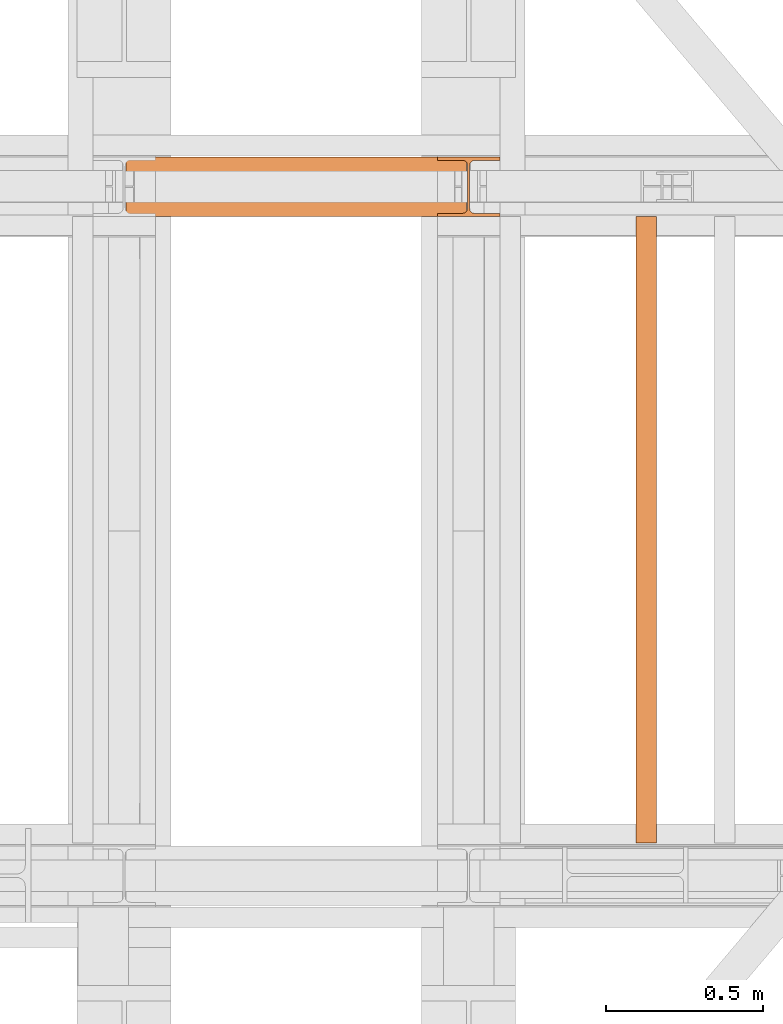
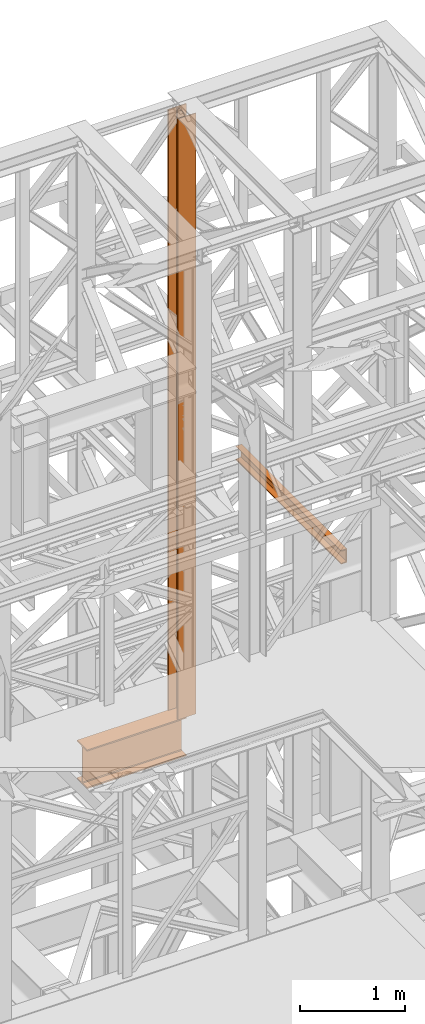
# One storey, part 171 of 208: 3 proxies.
"""IFC2X3 building model written with IfcOpenShell, lengths in millimetres."""

from ifc_helpers import new_model, entity, si_unit, converted_unit, frame, origin, origin_with_axes, place, context, subcontext, project, spatial, faceted_brep, element, save


model = new_model("IFC2X3")

# Units and contexts
model_context = context("Model", 3, precision=1e-05, world=origin())
plan_context = context("Plan", 3, precision=1e-05, world=origin())
body_context = subcontext(model_context, "Body", "Model", "MODEL_VIEW")
ifc_project = project(units=[si_unit("LENGTHUNIT", "METRE", prefix="MILLI"), converted_unit("PLANEANGLEUNIT", "DEGREE", entity("IfcPlaneAngleMeasure", 0.0174532925199433), si_unit("PLANEANGLEUNIT", "RADIAN"), dimensions=[0, 0, 0, 0, 0, 0, 0]), si_unit("AREAUNIT", "SQUARE_METRE"), si_unit("VOLUMEUNIT", "CUBIC_METRE")], contexts=[model_context, plan_context])

# Building, storey
building_placement = place(None, origin())
building = spatial("IfcBuilding", under=ifc_project, at=building_placement, CompositionType="COMPLEX")
storey_placement = place(building_placement, origin_with_axes())
storey = spatial("IfcBuildingStorey", under=building, at=storey_placement, Name="Geschoss", CompositionType="ELEMENT")

# Proxies
proxy_1_placement = place(storey_placement, frame((5499.254968580828, -13857.57439657637, 4834.989987483023), z_axis=(0.0, 0.0, 1.0), x_axis=(1.0, 0.0, 0.0)))
element("IfcBuildingElementProxy", 1, at=proxy_1_placement, inside=storey, context=body_context, shape_type="Brep", body=[
    faceted_brep([(1088.009999895696, 0.01000000000021828, 450.0100178813937), (1088.009999895696, 190.0100125169756, 450.0100178813937), (1088.009999895696, 190.0100125169756, 435.4100240564349), (1088.009999895696, 120.7100073045494, 435.4100091552737), (1088.009999895696, 109.841562265754, 433.2347078418734), (1088.009999895696, 101.8853126263621, 425.2784563398363), (1088.009999895696, 99.71000619068764, 414.4100113010409), (1088.009999895696, 99.71000619068764, 35.60999167919181), (1088.009999895696, 101.8853126263621, 24.74154664039634), (1088.009999895696, 109.841562265754, 16.78529513835929), (1088.009999895696, 120.7100073045494, 14.60999382495902), (1088.009999895696, 190.0100125169756, 14.60999382495902), (1088.009999895696, 190.0100125169756, 0.01000000000021828), (1088.009999895696, 0.01000000000021828, 0.01000000000021828), (1088.009999895696, 0.01000000000021828, 14.60999382495902), (1088.009999895696, 69.3100052124264, 14.60999382495902), (1088.009999895696, 80.17845025122188, 16.78529513835929), (1088.009999895696, 88.13469989061377, 24.74154664039634), (1088.009999895696, 90.3100063262882, 35.60999167919181), (1088.009999895696, 90.3100063262882, 414.4100113010409), (1088.009999895696, 88.13469989061377, 425.2784563398363), (1088.009999895696, 80.17845025122188, 433.2347078418734), (1088.009999895696, 69.3100052124264, 435.4100091552737), (1088.009999895696, 0.01000000000021828, 435.4100240564349), (1088.009999895696, 190.0100125169756, 450.0100178813937), (1088.009999895696, 0.01000000000021828, 450.0100178813937), (0.01000000000021828, 0.01000000000021828, 450.0100178813937), (0.01000000000021828, 190.0100125169756, 450.0100178813937), (1088.009999895696, 190.0100125169756, 435.4100240564349), (1088.009999895696, 190.0100125169756, 450.0100178813937), (0.01000000000021828, 190.0100125169756, 450.0100178813937), (0.01000000000021828, 190.0100125169756, 435.4100240564349), (1088.009999895696, 120.7100073045494, 435.4100091552737), (1088.009999895696, 190.0100125169756, 435.4100240564349), (0.01000000000021828, 190.0100125169756, 435.4100240564349), (0.01000000000021828, 120.7100073045494, 435.4100091552737), (1088.009999895696, 109.841562265754, 433.2347078418734), (1088.009999895696, 120.7100073045494, 435.4100091552737), (0.01000000000021828, 120.7100073045494, 435.4100091552737), (0.01000000000021828, 109.841562265754, 433.2347078418734), (1088.009999895696, 101.8853126263621, 425.2784563398363), (1088.009999895696, 109.841562265754, 433.2347078418734), (0.01000000000021828, 109.841562265754, 433.2347078418734), (0.01000000000021828, 101.8853126263621, 425.2784563398363), (1088.009999895696, 99.71000619068764, 414.4100113010409), (1088.009999895696, 101.8853126263621, 425.2784563398363), (0.01000000000021828, 101.8853126263621, 425.2784563398363), (0.01000000000021828, 99.71000619068764, 414.4100113010409), (1088.009999895696, 99.71000619068764, 35.60999167919181), (1088.009999895696, 99.71000619068764, 414.4100113010409), (0.01000000000021828, 99.71000619068764, 414.4100113010409), (0.01000000000021828, 99.71000619068764, 35.60999167919181), (1088.009999895696, 101.8853126263621, 24.74154664039634), (1088.009999895696, 99.71000619068764, 35.60999167919181), (0.01000000000021828, 99.71000619068764, 35.60999167919181), (0.01000000000021828, 101.8853126263621, 24.74154664039634), (1088.009999895696, 109.841562265754, 16.78529513835929), (1088.009999895696, 101.8853126263621, 24.74154664039634), (0.01000000000021828, 101.8853126263621, 24.74154664039634), (0.01000000000021828, 109.841562265754, 16.78529513835929), (1088.009999895696, 120.7100073045494, 14.60999382495902), (1088.009999895696, 109.841562265754, 16.78529513835929), (0.01000000000021828, 109.841562265754, 16.78529513835929), (0.01000000000021828, 120.7100073045494, 14.60999382495902), (1088.009999895696, 190.0100125169756, 14.60999382495902), (1088.009999895696, 120.7100073045494, 14.60999382495902), (0.01000000000021828, 120.7100073045494, 14.60999382495902), (0.01000000000021828, 190.0100125169756, 14.60999382495902), (1088.009999895696, 190.0100125169756, 0.01000000000021828), (1088.009999895696, 190.0100125169756, 14.60999382495902), (0.01000000000021828, 190.0100125169756, 14.60999382495902), (0.01000000000021828, 190.0100125169756, 0.01000000000021828), (1088.009999895696, 0.01000000000021828, 0.01000000000021828), (1088.009999895696, 190.0100125169756, 0.01000000000021828), (0.01000000000021828, 190.0100125169756, 0.01000000000021828), (0.01000000000021828, 0.01000000000021828, 0.01000000000021828), (1088.009999895696, 0.01000000000021828, 14.60999382495902), (1088.009999895696, 0.01000000000021828, 0.01000000000021828), (0.01000000000021828, 0.01000000000021828, 0.01000000000021828), (0.01000000000021828, 0.01000000000021828, 14.60999382495902), (1088.009999895696, 69.3100052124264, 14.60999382495902), (1088.009999895696, 0.01000000000021828, 14.60999382495902), (0.01000000000021828, 0.01000000000021828, 14.60999382495902), (0.01000000000021828, 69.3100052124264, 14.60999382495902), (1088.009999895696, 80.17845025122188, 16.78529513835929), (1088.009999895696, 69.3100052124264, 14.60999382495902), (0.01000000000021828, 69.3100052124264, 14.60999382495902), (0.01000000000021828, 80.17845025122188, 16.78529513835929), (1088.009999895696, 88.13469989061377, 24.74154664039634), (1088.009999895696, 80.17845025122188, 16.78529513835929), (0.01000000000021828, 80.17845025122188, 16.78529513835929), (0.01000000000021828, 88.13469989061377, 24.74154664039634), (1088.009999895696, 90.3100063262882, 35.60999167919181), (1088.009999895696, 88.13469989061377, 24.74154664039634), (0.01000000000021828, 88.13469989061377, 24.74154664039634), (0.01000000000021828, 90.3100063262882, 35.60999167919181), (1088.009999895696, 90.3100063262882, 414.4100113010409), (1088.009999895696, 90.3100063262882, 35.60999167919181), (0.01000000000021828, 90.3100063262882, 35.60999167919181), (0.01000000000021828, 90.3100063262882, 414.4100113010409), (1088.009999895696, 88.13469989061377, 425.2784563398363), (1088.009999895696, 90.3100063262882, 414.4100113010409), (0.01000000000021828, 90.3100063262882, 414.4100113010409), (0.01000000000021828, 88.13469989061377, 425.2784563398363), (1088.009999895696, 80.17845025122188, 433.2347078418734), (1088.009999895696, 88.13469989061377, 425.2784563398363), (0.01000000000021828, 88.13469989061377, 425.2784563398363), (0.01000000000021828, 80.17845025122188, 433.2347078418734), (1088.009999895696, 69.3100052124264, 435.4100091552737), (1088.009999895696, 80.17845025122188, 433.2347078418734), (0.01000000000021828, 80.17845025122188, 433.2347078418734), (0.01000000000021828, 69.3100052124264, 435.4100091552737), (1088.009999895696, 0.01000000000021828, 435.4100240564349), (1088.009999895696, 69.3100052124264, 435.4100091552737), (0.01000000000021828, 69.3100052124264, 435.4100091552737), (0.01000000000021828, 0.01000000000021828, 435.4100240564349), (1088.009999895696, 0.01000000000021828, 450.0100178813937), (1088.009999895696, 0.01000000000021828, 435.4100240564349), (0.01000000000021828, 0.01000000000021828, 435.4100240564349), (0.01000000000021828, 0.01000000000021828, 450.0100178813937), (0.01000000000021828, 0.01000000000021828, 450.0100178813937), (0.01000000000021828, 0.01000000000021828, 435.4100240564349), (0.01000000000021828, 69.3100052124264, 435.4100091552737), (0.01000000000021828, 80.17845025122188, 433.2347078418734), (0.01000000000021828, 88.13469989061377, 425.2784563398363), (0.01000000000021828, 90.3100063262882, 414.4100113010409), (0.01000000000021828, 90.3100063262882, 35.60999167919181), (0.01000000000021828, 88.13469989061377, 24.74154664039634), (0.01000000000021828, 80.17845025122188, 16.78529513835929), (0.01000000000021828, 69.3100052124264, 14.60999382495902), (0.01000000000021828, 0.01000000000021828, 14.60999382495902), (0.01000000000021828, 0.01000000000021828, 0.01000000000021828), (0.01000000000021828, 190.0100125169756, 0.01000000000021828), (0.01000000000021828, 190.0100125169756, 14.60999382495902), (0.01000000000021828, 120.7100073045494, 14.60999382495902), (0.01000000000021828, 109.841562265754, 16.78529513835929), (0.01000000000021828, 101.8853126263621, 24.74154664039634), (0.01000000000021828, 99.71000619068764, 35.60999167919181), (0.01000000000021828, 99.71000619068764, 414.4100113010409), (0.01000000000021828, 101.8853126263621, 425.2784563398363), (0.01000000000021828, 109.841562265754, 433.2347078418734), (0.01000000000021828, 120.7100073045494, 435.4100091552737), (0.01000000000021828, 190.0100125169756, 435.4100240564349), (0.01000000000021828, 190.0100125169756, 450.0100178813937)], [[[0, 1, 2, 3, 4, 5, 6, 7, 8, 9, 10, 11, 12, 13, 14, 15, 16, 17, 18, 19, 20, 21, 22, 23]], [[24, 25, 26, 27]], [[28, 29, 30, 31]], [[32, 33, 34, 35]], [[36, 37, 38, 39]], [[40, 41, 42, 43]], [[44, 45, 46, 47]], [[48, 49, 50, 51]], [[52, 53, 54, 55]], [[56, 57, 58, 59]], [[60, 61, 62, 63]], [[64, 65, 66, 67]], [[68, 69, 70, 71]], [[72, 73, 74, 75]], [[76, 77, 78, 79]], [[80, 81, 82, 83]], [[84, 85, 86, 87]], [[88, 89, 90, 91]], [[92, 93, 94, 95]], [[96, 97, 98, 99]], [[100, 101, 102, 103]], [[104, 105, 106, 107]], [[108, 109, 110, 111]], [[112, 113, 114, 115]], [[116, 117, 118, 119]], [[120, 121, 122, 123, 124, 125, 126, 127, 128, 129, 130, 131, 132, 133, 134, 135, 136, 137, 138, 139, 140, 141, 142, 143]]], orient=[[False], [False], [False], [False], [False], [False], [False], [False], [False], [False], [False], [False], [False], [False], [False], [False], [False], [False], [False], [False], [False], [False], [False], [False], [False], [False]]),
])
proxy_2_placement = place(storey_placement, frame((6493.254967038551, -13857.57439657637, 5284.990005364415), z_axis=(0.0, 0.0, 1.0), x_axis=(1.0, 0.0, 0.0)))
element("IfcBuildingElementProxy", 2, at=proxy_2_placement, inside=storey, context=body_context, shape_type="Brep", body=[
    faceted_brep([(0.009999999999308784, 190.0100125169756, 6965.010053329393), (200.0100029802316, 190.0100125169756, 6965.010053329393), (200.0100029802316, 180.0100146031382, 6965.010053329393), (121.260003576278, 180.0100071525576, 6965.010053329393), (111.9441915473335, 178.1454621052744, 6965.010053329393), (105.1245498640828, 171.3258190250399, 6965.010053329393), (103.2600015571707, 162.010007927418, 6965.010053329393), (103.2600015571707, 28.00999713897727, 6965.010053329393), (105.1245498640828, 18.69418604135535, 6965.010053329393), (111.9441915473335, 11.87454296112082, 6965.010053329393), (121.260003576278, 10.00999791383765, 6965.010053329393), (200.0100029802316, 10.00999791383765, 6965.010053329393), (200.0100029802316, 0.01000000000021828, 6965.010053329393), (0.009999999999308784, 0.01000000000021828, 6965.010053329393), (0.009999999999308784, 10.00999791383765, 6965.010053329393), (78.75999940395286, 10.00999791383765, 6965.010053329393), (88.07581143289735, 11.87454296112082, 6965.010053329393), (94.89545311614802, 18.69418604135535, 6965.010053329393), (96.7600014230602, 28.00999713897727, 6965.010053329393), (96.7600014230602, 162.010007927418, 6965.010053329393), (94.89545311614802, 171.3258190250399, 6965.010053329393), (88.07581143289735, 178.1454621052744, 6965.010053329393), (78.75999940395286, 180.0100071525576, 6965.010053329393), (0.009999999999308784, 180.0100146031382, 6965.010053329393), (200.0100029802316, 190.0100125169756, 6965.010053329393), (0.009999999999308784, 190.0100125169756, 6965.010053329393), (0.01000000000021828, 190.0100125169756, 0.01000000000112777), (200.0100029802325, 190.0100125169756, 0.01000000000112777), (200.0100029802316, 180.0100146031382, 6965.010053329393), (200.0100029802316, 190.0100125169756, 6965.010053329393), (200.0100029802325, 190.0100125169756, 0.01000000000112777), (200.0100029802325, 180.0100146031382, 0.01000000000112777), (121.260003576278, 180.0100071525576, 6965.010053329393), (200.0100029802316, 180.0100146031382, 6965.010053329393), (200.0100029802325, 180.0100146031382, 0.01000000000112777), (121.2600035762789, 180.0100071525576, 0.01000000000112777), (111.9441915473335, 178.1454621052744, 6965.010053329393), (121.260003576278, 180.0100071525576, 6965.010053329393), (121.2600035762789, 180.0100071525576, 0.01000000000112777), (111.9441915473344, 178.1454621052744, 0.01000000000112777), (105.1245498640828, 171.3258190250399, 6965.010053329393), (111.9441915473335, 178.1454621052744, 6965.010053329393), (111.9441915473344, 178.1454621052744, 0.01000000000112777), (105.1245498640838, 171.3258190250399, 0.01000000000112777), (103.2600015571707, 162.010007927418, 6965.010053329393), (105.1245498640828, 171.3258190250399, 6965.010053329393), (105.1245498640838, 171.3258190250399, 0.01000000000112777), (103.2600015571716, 162.010007927418, 0.01000000000112777), (103.2600015571707, 28.00999713897727, 6965.010053329393), (103.2600015571707, 162.010007927418, 6965.010053329393), (103.2600015571716, 162.010007927418, 0.01000000000112777), (103.2600015571716, 28.00999713897727, 0.01000000000112777), (105.1245498640828, 18.69418604135535, 6965.010053329393), (103.2600015571707, 28.00999713897727, 6965.010053329393), (103.2600015571716, 28.00999713897727, 0.01000000000112777), (105.1245498640838, 18.69418604135535, 0.01000000000112777), (111.9441915473335, 11.87454296112082, 6965.010053329393), (105.1245498640828, 18.69418604135535, 6965.010053329393), (105.1245498640838, 18.69418604135535, 0.01000000000112777), (111.9441915473344, 11.87454296112082, 0.01000000000112777), (121.260003576278, 10.00999791383765, 6965.010053329393), (111.9441915473335, 11.87454296112082, 6965.010053329393), (111.9441915473344, 11.87454296112082, 0.01000000000112777), (121.2600035762789, 10.00999791383765, 0.01000000000112777), (200.0100029802316, 10.00999791383765, 6965.010053329393), (121.260003576278, 10.00999791383765, 6965.010053329393), (121.2600035762789, 10.00999791383765, 0.01000000000112777), (200.0100029802325, 10.00999791383765, 0.01000000000112777), (200.0100029802316, 0.01000000000021828, 6965.010053329393), (200.0100029802316, 10.00999791383765, 6965.010053329393), (200.0100029802325, 10.00999791383765, 0.01000000000112777), (200.0100029802325, 0.01000000000021828, 0.01000000000112777), (0.009999999999308784, 0.01000000000021828, 6965.010053329393), (200.0100029802316, 0.01000000000021828, 6965.010053329393), (200.0100029802325, 0.01000000000021828, 0.01000000000112777), (0.01000000000021828, 0.01000000000021828, 0.01000000000112777), (0.009999999999308784, 10.00999791383765, 6965.010053329393), (0.009999999999308784, 0.01000000000021828, 6965.010053329393), (0.01000000000021828, 0.01000000000021828, 0.01000000000112777), (0.01000000000021828, 10.00999791383765, 0.01000000000112777), (78.75999940395286, 10.00999791383765, 6965.010053329393), (0.009999999999308784, 10.00999791383765, 6965.010053329393), (0.01000000000021828, 10.00999791383765, 0.01000000000112777), (78.75999940395377, 10.00999791383765, 0.01000000000112777), (88.07581143289735, 11.87454296112082, 6965.010053329393), (78.75999940395286, 10.00999791383765, 6965.010053329393), (78.75999940395377, 10.00999791383765, 0.01000000000112777), (88.07581143289826, 11.87454296112082, 0.01000000000112777), (94.89545311614802, 18.69418604135535, 6965.010053329393), (88.07581143289735, 11.87454296112082, 6965.010053329393), (88.07581143289826, 11.87454296112082, 0.01000000000112777), (94.89545311614893, 18.69418604135535, 0.01000000000112777), (96.7600014230602, 28.00999713897727, 6965.010053329393), (94.89545311614802, 18.69418604135535, 6965.010053329393), (94.89545311614893, 18.69418604135535, 0.01000000000112777), (96.76000142306111, 28.00999713897727, 0.01000000000112777), (96.7600014230602, 162.010007927418, 6965.010053329393), (96.7600014230602, 28.00999713897727, 6965.010053329393), (96.76000142306111, 28.00999713897727, 0.01000000000112777), (96.76000142306111, 162.010007927418, 0.01000000000112777), (94.89545311614802, 171.3258190250399, 6965.010053329393), (96.7600014230602, 162.010007927418, 6965.010053329393), (96.76000142306111, 162.010007927418, 0.01000000000112777), (94.89545311614893, 171.3258190250399, 0.01000000000112777), (88.07581143289735, 178.1454621052744, 6965.010053329393), (94.89545311614802, 171.3258190250399, 6965.010053329393), (94.89545311614893, 171.3258190250399, 0.01000000000112777), (88.07581143289826, 178.1454621052744, 0.01000000000112777), (78.75999940395286, 180.0100071525576, 6965.010053329393), (88.07581143289735, 178.1454621052744, 6965.010053329393), (88.07581143289826, 178.1454621052744, 0.01000000000112777), (78.75999940395377, 180.0100071525576, 0.01000000000112777), (0.009999999999308784, 180.0100146031382, 6965.010053329393), (78.75999940395286, 180.0100071525576, 6965.010053329393), (78.75999940395377, 180.0100071525576, 0.01000000000112777), (0.01000000000021828, 180.0100146031382, 0.01000000000112777), (0.009999999999308784, 190.0100125169756, 6965.010053329393), (0.009999999999308784, 180.0100146031382, 6965.010053329393), (0.01000000000021828, 180.0100146031382, 0.01000000000112777), (0.01000000000021828, 190.0100125169756, 0.01000000000112777), (0.01000000000021828, 190.0100125169756, 0.01000000000112777), (0.01000000000021828, 180.0100146031382, 0.01000000000112777), (78.75999940395377, 180.0100071525576, 0.01000000000112777), (88.07581143289826, 178.1454621052744, 0.01000000000112777), (94.89545311614893, 171.3258190250399, 0.01000000000112777), (96.76000142306111, 162.010007927418, 0.01000000000112777), (96.76000142306111, 28.00999713897727, 0.01000000000112777), (94.89545311614893, 18.69418604135535, 0.01000000000112777), (88.07581143289826, 11.87454296112082, 0.01000000000112777), (78.75999940395377, 10.00999791383765, 0.01000000000112777), (0.01000000000021828, 10.00999791383765, 0.01000000000112777), (0.01000000000021828, 0.01000000000021828, 0.01000000000112777), (200.0100029802325, 0.01000000000021828, 0.01000000000112777), (200.0100029802325, 10.00999791383765, 0.01000000000112777), (121.2600035762789, 10.00999791383765, 0.01000000000112777), (111.9441915473344, 11.87454296112082, 0.01000000000112777), (105.1245498640838, 18.69418604135535, 0.01000000000112777), (103.2600015571716, 28.00999713897727, 0.01000000000112777), (103.2600015571716, 162.010007927418, 0.01000000000112777), (105.1245498640838, 171.3258190250399, 0.01000000000112777), (111.9441915473344, 178.1454621052744, 0.01000000000112777), (121.2600035762789, 180.0100071525576, 0.01000000000112777), (200.0100029802325, 180.0100146031382, 0.01000000000112777), (200.0100029802325, 190.0100125169756, 0.01000000000112777)], [[[0, 1, 2, 3, 4, 5, 6, 7, 8, 9, 10, 11, 12, 13, 14, 15, 16, 17, 18, 19, 20, 21, 22, 23]], [[24, 25, 26, 27]], [[28, 29, 30, 31]], [[32, 33, 34, 35]], [[36, 37, 38, 39]], [[40, 41, 42, 43]], [[44, 45, 46, 47]], [[48, 49, 50, 51]], [[52, 53, 54, 55]], [[56, 57, 58, 59]], [[60, 61, 62, 63]], [[64, 65, 66, 67]], [[68, 69, 70, 71]], [[72, 73, 74, 75]], [[76, 77, 78, 79]], [[80, 81, 82, 83]], [[84, 85, 86, 87]], [[88, 89, 90, 91]], [[92, 93, 94, 95]], [[96, 97, 98, 99]], [[100, 101, 102, 103]], [[104, 105, 106, 107]], [[108, 109, 110, 111]], [[112, 113, 114, 115]], [[116, 117, 118, 119]], [[120, 121, 122, 123, 124, 125, 126, 127, 128, 129, 130, 131, 132, 133, 134, 135, 136, 137, 138, 139, 140, 141, 142, 143]]], orient=[[False], [False], [False], [False], [False], [False], [False], [False], [False], [False], [False], [False], [False], [False], [False], [False], [False], [False], [False], [False], [False], [False], [False], [False], [False], [False]]),
])
proxy_3_placement = place(storey_placement, frame((7128.254968528667, -15857.57439274273, 8078.360005364419), z_axis=(0.0, 0.0, 1.0), x_axis=(1.0, 0.0, 0.0)))
element("IfcBuildingElementProxy", 3, at=proxy_3_placement, inside=storey, context=body_context, shape_type="Brep", body=[
    faceted_brep([(65.01000000000022, 2000.009997019768, 160.0100000000002), (65.01000000000204, 0.01000000000021828, 160.0100000000002), (0.01000000000203727, 0.01000000000021828, 160.0100000000002), (0.01000000000021828, 2000.009997019768, 160.0100000000002), (0.01000000000021828, 2000.009997019768, 160.0100000000002), (0.01000000000203727, 0.01000000000021828, 160.0100000000002), (0.01000000000203727, 0.01000000000021828, 156.8875719297539), (0.01000000000021828, 2000.009997019768, 156.8875719297539), (0.01000000000021828, 2000.009997019768, 156.8875719297539), (0.01000000000203727, 0.01000000000021828, 156.8875719297539), (0.2527365771748009, 0.01000000000021828, 155.2717110918293), (0.2527365771729819, 2000.009997019768, 155.2717110918293), (0.2527365771729819, 2000.009997019768, 155.2717110918293), (0.2527365771748009, 0.01000000000021828, 155.2717110918293), (0.9594677141431021, 0.01000000000021828, 153.7984655565542), (0.959467714144921, 2000.009997019768, 153.7984655565542), (0.959467714144921, 2000.009997019768, 153.7984655565542), (0.9594677141431021, 0.01000000000021828, 153.7984655565542), (2.067848361533834, 0.01000000000021828, 152.5978732961266), (2.067848361532015, 2000.009997019768, 152.5978732961266), (2.067848361532015, 2000.009997019768, 152.5978732961266), (2.067848361533834, 0.01000000000021828, 152.5978732961266), (3.480043588519038, 0.01000000000021828, 151.7759086082897), (3.480043588517219, 2000.009997019768, 151.7759086082897), (3.480043588517219, 2000.009997019768, 151.7759086082897), (3.480043588519038, 0.01000000000021828, 151.7759086082897), (5.071401277447876, 0.01000000000021828, 151.4050878978051), (5.071401277446057, 2000.009997019768, 151.4050878978051), (5.071401277446057, 2000.009997019768, 151.4050878978051), (5.071401277447876, 0.01000000000021828, 151.4050878978051), (47.84732483397238, 0.01000000000021828, 147.9830140132835), (47.84732483397056, 2000.009997019768, 147.9830140132835), (47.84732483397056, 2000.009997019768, 147.9830140132835), (47.84732483397238, 0.01000000000021828, 147.9830140132835), (50.81159179199312, 0.01000000000021828, 147.318026761528), (50.8115917919913, 2000.009997019768, 147.318026761528), (50.8115917919913, 2000.009997019768, 147.318026761528), (50.81159179199312, 0.01000000000021828, 147.318026761528), (53.58138040071208, 0.01000000000021828, 145.7058782528511), (53.5813804007139, 2000.009997019768, 145.7058782528511), (53.5813804007139, 2000.009997019768, 145.7058782528511), (53.58138040071208, 0.01000000000021828, 145.7058782528511), (55.69737981845537, 0.01000000000021828, 143.4138384829421), (55.69737981845356, 2000.009997019768, 143.4138384829421), (55.69737981845356, 2000.009997019768, 143.4138384829421), (55.69737981845537, 0.01000000000021828, 143.4138384829421), (57.04659380721569, 0.01000000000021828, 140.6012788246917), (57.04659380721387, 2000.009997019768, 140.6012788246917), (57.04659380721387, 2000.009997019768, 140.6012788246917), (57.04659380721569, 0.01000000000021828, 140.6012788246917), (57.51000000000204, 0.01000000000021828, 137.5164535886543), (57.51000000000022, 2000.009997019768, 137.5164535886543), (57.51000000000022, 2000.009997019768, 137.5164535886543), (57.51000000000204, 0.01000000000021828, 137.5164535886543), (57.51000000000204, 0.01000000000021828, 22.503546411348), (57.51000000000022, 2000.009997019768, 22.503546411348), (57.51000000000022, 2000.009997019768, 22.503546411348), (57.51000000000204, 0.01000000000021828, 22.503546411348), (57.04659380721569, 0.01000000000021828, 19.41872117530875), (57.04659380721387, 2000.009997019768, 19.41872117530875), (57.04659380721387, 2000.009997019768, 19.41872117530875), (57.04659380721569, 0.01000000000021828, 19.41872117530875), (55.69737981845537, 0.01000000000021828, 16.60616151705835), (55.69737981845356, 2000.009997019768, 16.60616151705835), (55.69737981845356, 2000.009997019768, 16.60616151705835), (55.69737981845537, 0.01000000000021828, 16.60616151705835), (53.58138040071208, 0.01000000000021828, 14.31412174714933), (53.5813804007139, 2000.009997019768, 14.31412174714933), (53.5813804007139, 2000.009997019768, 14.31412174714933), (53.58138040071208, 0.01000000000021828, 14.31412174714933), (50.88537133101636, 0.01000000000021828, 12.74491643400688), (50.88537133101818, 2000.009997019768, 12.74491643400688), (50.88537133101818, 2000.009997019768, 12.74491643400688), (50.88537133101636, 0.01000000000021828, 12.74491643400688), (47.84732483397238, 0.01000000000021828, 12.03698598671872), (47.84732483397056, 2000.009997019768, 12.03698598671872), (47.84732483397056, 2000.009997019768, 12.03698598671872), (47.84732483397238, 0.01000000000021828, 12.03698598671872), (5.071401277447876, 0.01000000000021828, 8.614912102195376), (5.071401277446057, 2000.009997019768, 8.614912102195376), (5.071401277446057, 2000.009997019768, 8.614912102195376), (5.071401277447876, 0.01000000000021828, 8.614912102195376), (3.480043588519038, 0.01000000000021828, 8.244091391710754), (3.480043588517219, 2000.009997019768, 8.244091391710754), (3.480043588517219, 2000.009997019768, 8.244091391710754), (3.480043588519038, 0.01000000000021828, 8.244091391710754), (2.067848361533834, 0.01000000000021828, 7.422126703873801), (2.067848361532015, 2000.009997019768, 7.422126703873801), (2.067848361532015, 2000.009997019768, 7.422126703873801), (2.067848361533834, 0.01000000000021828, 7.422126703873801), (0.9594677141431021, 0.01000000000021828, 6.221534443446217), (0.959467714144921, 2000.009997019768, 6.221534443446217), (0.959467714144921, 2000.009997019768, 6.221534443446217), (0.9594677141431021, 0.01000000000021828, 6.221534443446217), (0.2527365771748009, 0.01000000000021828, 4.748288908172981), (0.2527365771729819, 2000.009997019768, 4.748288908172981), (0.2527365771729819, 2000.009997019768, 4.748288908172981), (0.2527365771748009, 0.01000000000021828, 4.748288908172981), (0.01000000000203727, 0.01000000000021828, 0.01000000000021828), (0.01000000000021828, 2000.009997019768, 0.01000000000021828), (0.01000000000021828, 2000.009997019768, 0.01000000000021828), (0.01000000000203727, 0.01000000000021828, 0.01000000000021828), (65.01000000000204, 0.01000000000021828, 0.01000000000021828), (65.01000000000022, 2000.009997019768, 0.01000000000021828), (65.01000000000022, 2000.009997019768, 0.01000000000021828), (65.01000000000204, 0.01000000000021828, 0.01000000000021828), (65.01000000000204, 0.01000000000021828, 160.0100000000002), (65.01000000000022, 2000.009997019768, 160.0100000000002), (65.01000000000022, 2000.009997019768, 160.0100000000002), (0.01000000000021828, 2000.009997019768, 160.0100000000002), (0.01000000000021828, 2000.009997019768, 156.8875719297539), (0.2527365771729819, 2000.009997019768, 155.2717110918293), (0.959467714144921, 2000.009997019768, 153.7984655565542), (2.067848361532015, 2000.009997019768, 152.5978732961266), (3.480043588517219, 2000.009997019768, 151.7759086082897), (5.071401277446057, 2000.009997019768, 151.4050878978051), (47.84732483397056, 2000.009997019768, 147.9830140132835), (50.8115917919913, 2000.009997019768, 147.318026761528), (53.5813804007139, 2000.009997019768, 145.7058782528511), (55.69737981845356, 2000.009997019768, 143.4138384829421), (57.04659380721387, 2000.009997019768, 140.6012788246917), (57.51000000000022, 2000.009997019768, 137.5164535886543), (57.51000000000022, 2000.009997019768, 22.503546411348), (57.04659380721387, 2000.009997019768, 19.41872117530875), (55.69737981845356, 2000.009997019768, 16.60616151705835), (53.5813804007139, 2000.009997019768, 14.31412174714933), (50.88537133101818, 2000.009997019768, 12.74491643400688), (47.84732483397056, 2000.009997019768, 12.03698598671872), (5.071401277446057, 2000.009997019768, 8.614912102195376), (3.480043588517219, 2000.009997019768, 8.244091391710754), (2.067848361532015, 2000.009997019768, 7.422126703873801), (0.959467714144921, 2000.009997019768, 6.221534443446217), (0.2527365771729819, 2000.009997019768, 4.748288908172981), (0.01000000000021828, 2000.009997019768, 0.01000000000021828), (65.01000000000022, 2000.009997019768, 0.01000000000021828), (65.01000000000204, 0.01000000000021828, 160.0100000000002), (65.01000000000204, 0.01000000000021828, 0.01000000000021828), (0.01000000000203727, 0.01000000000021828, 0.01000000000021828), (0.2527365771748009, 0.01000000000021828, 4.748288908172981), (0.9594677141431021, 0.01000000000021828, 6.221534443446217), (2.067848361533834, 0.01000000000021828, 7.422126703873801), (3.480043588519038, 0.01000000000021828, 8.244091391710754), (5.071401277447876, 0.01000000000021828, 8.614912102195376), (47.84732483397238, 0.01000000000021828, 12.03698598671872), (50.88537133101636, 0.01000000000021828, 12.74491643400688), (53.58138040071208, 0.01000000000021828, 14.31412174714933), (55.69737981845537, 0.01000000000021828, 16.60616151705835), (57.04659380721569, 0.01000000000021828, 19.41872117530875), (57.51000000000204, 0.01000000000021828, 22.503546411348), (57.51000000000204, 0.01000000000021828, 137.5164535886543), (57.04659380721569, 0.01000000000021828, 140.6012788246917), (55.69737981845537, 0.01000000000021828, 143.4138384829421), (53.58138040071208, 0.01000000000021828, 145.7058782528511), (50.81159179199312, 0.01000000000021828, 147.318026761528), (47.84732483397238, 0.01000000000021828, 147.9830140132835), (5.071401277447876, 0.01000000000021828, 151.4050878978051), (3.480043588519038, 0.01000000000021828, 151.7759086082897), (2.067848361533834, 0.01000000000021828, 152.5978732961266), (0.9594677141431021, 0.01000000000021828, 153.7984655565542), (0.2527365771748009, 0.01000000000021828, 155.2717110918293), (0.01000000000203727, 0.01000000000021828, 156.8875719297539), (0.01000000000203727, 0.01000000000021828, 160.0100000000002)], [[[0, 1, 2, 3]], [[4, 5, 6, 7]], [[8, 9, 10, 11]], [[12, 13, 14, 15]], [[16, 17, 18, 19]], [[20, 21, 22, 23]], [[24, 25, 26, 27]], [[28, 29, 30, 31]], [[32, 33, 34, 35]], [[36, 37, 38, 39]], [[40, 41, 42, 43]], [[44, 45, 46, 47]], [[48, 49, 50, 51]], [[52, 53, 54, 55]], [[56, 57, 58, 59]], [[60, 61, 62, 63]], [[64, 65, 66, 67]], [[68, 69, 70, 71]], [[72, 73, 74, 75]], [[76, 77, 78, 79]], [[80, 81, 82, 83]], [[84, 85, 86, 87]], [[88, 89, 90, 91]], [[92, 93, 94, 95]], [[96, 97, 98, 99]], [[100, 101, 102, 103]], [[104, 105, 106, 107]], [[108, 109, 110, 111, 112, 113, 114, 115, 116, 117, 118, 119, 120, 121, 122, 123, 124, 125, 126, 127, 128, 129, 130, 131, 132, 133, 134]], [[135, 136, 137, 138, 139, 140, 141, 142, 143, 144, 145, 146, 147, 148, 149, 150, 151, 152, 153, 154, 155, 156, 157, 158, 159, 160, 161]]], orient=[[False], [False], [False], [False], [False], [False], [False], [False], [False], [False], [False], [False], [False], [False], [False], [False], [False], [False], [False], [False], [False], [False], [False], [False], [False], [False], [False], [False], [False]]),
])

save(model, "model.ifc")
